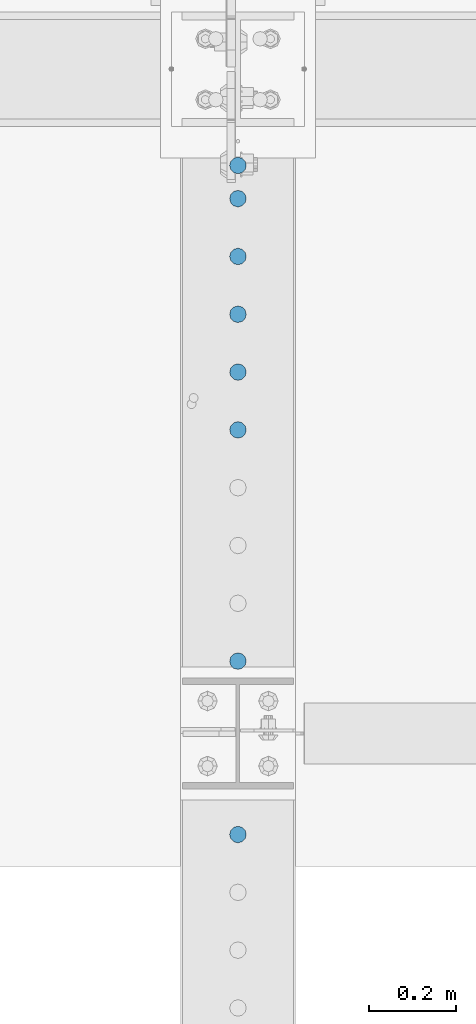
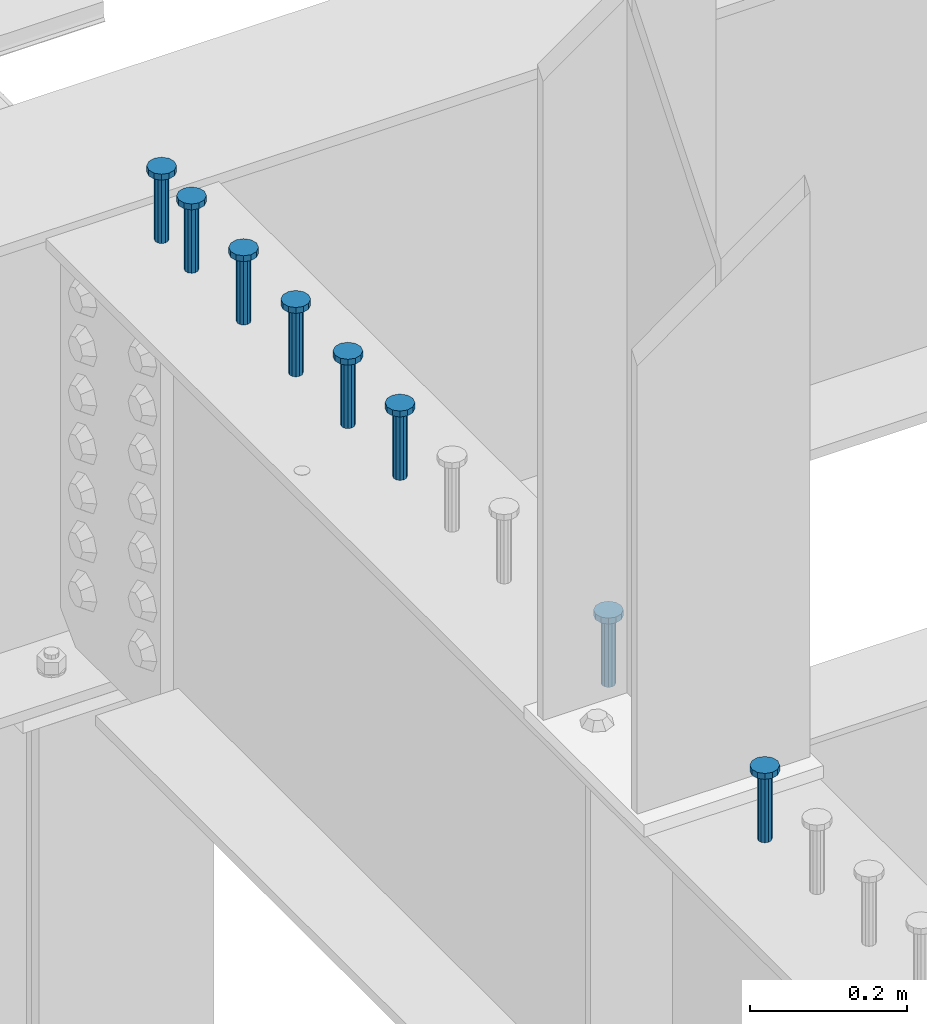
# One storey, part 950 of 1763: 8 columns, 8 elements without a shape of their own.
"""IFC2X3 building model written with IfcOpenShell, lengths in millimetres."""

import ifcopenshell
import ifcopenshell.guid

model = None  # the IFC model being written
_history = None  # IfcOwnerHistory: only IFC2X3 demands one
_inside = {}  # id of a spatial element -> (the spatial element, [elements in it])
_under = {}  # id of a project, library or spatial element -> (it, [spatial elements below it])
_declared = {}  # id of a project -> (the project, [libraries it declares])
_typed = {}  # id of a type object -> (the type object, [elements of that type])
_made_of = {}  # id of a material, layer set ... -> (it, [elements and type objects made of it])


def new_model(schema):
    """Start an empty IFC model of exactly this schema.

    Asked for "IFC4X3", IfcOpenShell would pick the latest addendum, in which some entities
    have other attributes; the version numbers below select the first issue.
    IFC2X3 requires an IfcOwnerHistory on every rooted entity: one is made here for all.
    """
    global model, _history
    if schema == "IFC4X3":
        model = ifcopenshell.file(schema_version=(4, 3, 0, 0))
    else:
        model = ifcopenshell.file(schema=schema)
    _inside.clear()
    _under.clear()
    _declared.clear()
    _typed.clear()
    _made_of.clear()
    _history = None
    if model.schema == "IFC2X3":
        org = make("IfcOrganization", Name="unknown")
        user = make(
            "IfcPersonAndOrganization",
            ThePerson=make("IfcPerson", FamilyName="unknown"),
            TheOrganization=org,
        )
        app = make(
            "IfcApplication",
            ApplicationDeveloper=org,
            Version="unknown",
            ApplicationFullName="unknown",
            ApplicationIdentifier="unknown",
        )
        _history = make(
            "IfcOwnerHistory",
            OwningUser=user,
            OwningApplication=app,
            ChangeAction="ADDED",
            CreationDate=0,
        )
    return model


def make(cls, **values):
    """One entity of the class cls with the attributes given. An attribute that is None is left unset."""
    return model.create_entity(
        cls, **{name: value for name, value in values.items() if value is not None}
    )


def rooted(cls, **values):
    """An entity with a GlobalId (a new one), such as an element, a storey or a relation."""
    return make(cls, GlobalId=ifcopenshell.guid.new(), OwnerHistory=_history, **values)


def si_unit(unit_type, name, prefix=None):
    """IfcSIUnit, for example si_unit("LENGTHUNIT", "METRE", prefix="MILLI")."""
    return make("IfcSIUnit", UnitType=unit_type, Prefix=prefix, Name=name)


def assignment(units):
    """IfcUnitAssignment: the units of a project."""
    return None if units is None else make("IfcUnitAssignment", Units=units)


def point(xyz):
    """IfcCartesianPoint."""
    return None if xyz is None else make("IfcCartesianPoint", Coordinates=xyz)


def direction(xyz):
    """IfcDirection."""
    return None if xyz is None else make("IfcDirection", DirectionRatios=xyz)


def frame(location, z_axis=None, x_axis=None):
    """IfcAxis2Placement3D, a coordinate frame: its origin and axes. An axis left out is left unset."""
    return make(
        "IfcAxis2Placement3D",
        Location=point(location),
        Axis=direction(z_axis),
        RefDirection=direction(x_axis),
    )


def origin_with_axes():
    """The frame at (0, 0, 0) with the z axis (0, 0, 1) and the x axis (1, 0, 0) written out."""
    return frame((0.0, 0.0, 0.0), z_axis=(0.0, 0.0, 1.0), x_axis=(1.0, 0.0, 0.0))


def place(relative_to, where):
    """IfcLocalPlacement: puts the frame where relative to a parent placement (None: the world)."""
    return make(
        "IfcLocalPlacement", PlacementRelTo=relative_to, RelativePlacement=where
    )


def context(
    kind, dimensions, precision=None, world=None, true_north=None, identifier=None
):
    """IfcGeometricRepresentationContext, for example the 3D "Model" context."""
    return make(
        "IfcGeometricRepresentationContext",
        ContextIdentifier=identifier,
        ContextType=kind,
        CoordinateSpaceDimension=dimensions,
        Precision=precision,
        WorldCoordinateSystem=world,
        TrueNorth=true_north,
    )


def subcontext(parent, identifier, kind, view, scale=None):
    """IfcGeometricRepresentationSubContext, for example "Body" below "Model"."""
    return make(
        "IfcGeometricRepresentationSubContext",
        ContextIdentifier=identifier,
        ContextType=kind,
        ParentContext=parent,
        TargetScale=scale,
        TargetView=view,
    )


def project(units=None, contexts=None):
    """IfcProject with its units and contexts."""
    return rooted(
        "IfcProject",
        Name="project",
        RepresentationContexts=contexts,
        UnitsInContext=assignment(units),
    )


def spatial(cls, under=None, at=None, **own):
    """A site, building, storey or space (cls), placed at a placement, below another one or the project."""
    s = rooted(cls, ObjectPlacement=at, **own)
    if under is not None:
        _under.setdefault(under.id(), (under, []))[1].append(s)
    return s


def faces_of(points, faces, orient=None, outer=None):
    """IfcFace entities. A face is a list of loops; a loop is a list of indices into points, from 0.

    orient and outer hold one flag for each loop. By default every Orientation is true, the
    first loop of a face is its IfcFaceOuterBound and the others are IfcFaceBound.
    """
    made = []
    for i, loops in enumerate(faces):
        bounds = []
        for j, loop in enumerate(loops):
            is_outer = j == 0 if outer is None else outer[i][j]
            bounds.append(
                make(
                    "IfcFaceOuterBound" if is_outer else "IfcFaceBound",
                    Bound=make("IfcPolyLoop", Polygon=[points[k] for k in loop]),
                    Orientation=True if orient is None else orient[i][j],
                )
            )
        made.append(make("IfcFace", Bounds=bounds))
    return made


def faceted_brep(points, faces, orient=None, outer=None, voids=None):
    """IfcFacetedBrep: a solid bounded by flat faces; with voids (closed shells), ...WithVoids."""
    shared = [point(p) for p in points]
    hull = make("IfcClosedShell", CfsFaces=faces_of(shared, faces, orient, outer))
    if voids is None:
        return make("IfcFacetedBrep", Outer=hull)
    return make(
        "IfcFacetedBrepWithVoids",
        Outer=hull,
        Voids=[
            make(cls, CfsFaces=faces_of(shared, fs, o, b)) for cls, fs, o, b in voids
        ],
    )


def shape(context_of_items, identifier, shape_type, items):
    """IfcShapeRepresentation: the items that make up one representation, for example the "Body"."""
    return make(
        "IfcShapeRepresentation",
        ContextOfItems=context_of_items,
        RepresentationIdentifier=identifier,
        RepresentationType=shape_type,
        Items=items,
    )


def material(Name=None, Category=None):
    """IfcMaterial."""
    return make("IfcMaterial", Name=Name, Category=Category)


def made_of(thing, what):
    """Note that an element or type object is made of a material, layer set ...; save() writes the relation."""
    if what is not None:
        _made_of.setdefault(what.id(), (what, []))[1].append(thing)
    return thing


def type_object(cls, material=None, **own):
    """A type object (cls), such as IfcWallType, which elements share."""
    return made_of(rooted(cls, **own), material)


def element(
    cls,
    number,
    at=None,
    inside=None,
    cuts=None,
    type_object=None,
    material=None,
    context=None,
    identifier="Body",
    shape_type=None,
    held_by="IfcProductDefinitionShape",
    body=None,
    shapes=None,
    **own,
):
    """One element of the class cls, such as IfcWall. Its Tag is "e" and its number.

    at: its placement. inside: the storey or other place that contains it. cuts: it is an
    opening in that element (IfcRelVoidsElement). A single representation is given by context,
    identifier, shape_type and body (its items); several are given by shapes. held_by: the class
    of the entity that holds the representations. save() writes the other relations.
    """
    e = rooted(cls, Tag="e%d" % number, ObjectPlacement=at, **own)
    if body is not None:
        shapes = [shape(context, identifier, shape_type, body)]
    if shapes is not None:
        e.Representation = make(held_by, Representations=shapes)
    if inside is not None:
        _inside.setdefault(inside.id(), (inside, []))[1].append(e)
    if cuts is not None:
        rooted(
            "IfcRelVoidsElement", RelatingBuildingElement=cuts, RelatedOpeningElement=e
        )
    if type_object is not None:
        _typed.setdefault(type_object.id(), (type_object, []))[1].append(e)
    return made_of(e, material)


def aggregate(whole, parts):
    """IfcRelAggregates: a whole, such as a stair, and the parts it consists of."""
    return rooted("IfcRelAggregates", RelatingObject=whole, RelatedObjects=parts)


def save(model, path):
    """Write the relations noted so far, then the file.

    IfcRelAggregates (storeys below a building ...), IfcRelContainedInSpatialStructure (elements
    in a storey), IfcRelDefinesByType, IfcRelAssociatesMaterial and IfcRelDeclares: one each for
    every whole, place, type object, material and project.
    """
    for whole, parts in _under.values():
        aggregate(whole, parts)
    for where, things in _inside.values():
        rooted(
            "IfcRelContainedInSpatialStructure",
            RelatedElements=things,
            RelatingStructure=where,
        )
    for kind, things in _typed.values():
        rooted("IfcRelDefinesByType", RelatedObjects=things, RelatingType=kind)
    for what, things in _made_of.values():
        rooted("IfcRelAssociatesMaterial", RelatedObjects=things, RelatingMaterial=what)
    for by, libraries in _declared.values():
        rooted("IfcRelDeclares", RelatingContext=by, RelatedDefinitions=libraries)
    model.write(path)


model = new_model("IFC2X3")

# Units and contexts
model_context = context("Model", 3, precision=1e-05, world=origin_with_axes())
body_context = subcontext(model_context, "Body", "Model", "MODEL_VIEW")
ifc_project = project(units=[si_unit("LENGTHUNIT", "METRE", prefix="MILLI"), si_unit("AREAUNIT", "SQUARE_METRE"), si_unit("VOLUMEUNIT", "CUBIC_METRE"), si_unit("MASSUNIT", "GRAM", prefix="KILO"), si_unit("TIMEUNIT", "SECOND"), si_unit("PLANEANGLEUNIT", "RADIAN"), si_unit("SOLIDANGLEUNIT", "STERADIAN"), si_unit("THERMODYNAMICTEMPERATUREUNIT", "DEGREE_CELSIUS"), si_unit("LUMINOUSINTENSITYUNIT", "LUMEN")], contexts=[model_context])

# Site, building, storey
site_placement = place(None, origin_with_axes())
site = spatial("IfcSite", under=ifc_project, at=site_placement, CompositionType="ELEMENT")
building_placement = place(site_placement, origin_with_axes())
building = spatial("IfcBuilding", under=site, at=building_placement, Name="Undefined", CompositionType="ELEMENT")
storey_placement = place(building_placement, origin_with_axes())
storey = spatial("IfcBuildingStorey", under=building, at=storey_placement, Name="Undefined", CompositionType="ELEMENT", Elevation=0.0)

# Assembly, column
assembly_1_placement = place(storey_placement, origin_with_axes())
assembly_1 = element("IfcElementAssembly", 1, at=assembly_1_placement, inside=storey, Name="STUD", AssemblyPlace="NOTDEFINED", PredefinedType="RIGID_FRAME")
ifc_material = material(Name="STEEL/A108")
column_type = type_object("IfcColumnType", Name="STUD_3/4-DIA", PredefinedType="NOTDEFINED")
column_1_placement = place(assembly_1_placement, frame((-24027.8372736984, 44584.9185, 5194.3), z_axis=(-1.0, 0.0, 0.0), x_axis=(0.0, 0.0, 1.0)))
column_1 = element("IfcColumn", 2, at=column_1_placement, type_object=column_type, material=ifc_material, Name="STUD", ObjectType="STUD_3/4-DIA", context=body_context, shape_type="Brep", body=[
    faceted_brep([(0.0, -9.52000045776367, 0.0), (0.0, -8.25, -4.76000022888184), (104.013, -8.25, -4.76000022888184), (104.013, -9.52000045776367, 0.0), (0.0, -4.76000022888184, -8.25), (104.013, -4.76000022888184, -8.25), (0.0, 0.0, -9.52000045776367), (104.013, 0.0, -9.52000045776367), (0.0, 4.76000022888184, -8.25), (104.013, 4.76000022888184, -8.25), (0.0, 8.25, -4.76000022888184), (104.013, 8.25, -4.76000022888184), (0.0, 9.52000045776367, 0.0), (104.013, 9.52000045776367, 0.0), (0.0, 8.25, 4.76000022888184), (104.013, 8.25, 4.76000022888184), (0.0, 4.76000022888184, 8.25), (104.013, 4.76000022888184, 8.25), (0.0, 0.0, 9.52000045776367), (104.013, 0.0, 9.52000045776367), (0.0, -4.76000022888184, 8.25), (104.013, -4.76000022888184, 8.25), (0.0, -8.25, 4.76000022888184), (104.013, -8.25, 4.76000022888184), (105.156, -16.5, -9.52000045776367), (105.156, -19.0499992370605, 0.0), (105.156, -9.52000045776367, -16.5), (105.156, 0.0, -19.0499992370605), (105.156, 9.52000045776367, -16.5), (105.156, 16.5, -9.52000045776367), (105.156, 19.0499992370605, 0.0), (105.156, 16.5, 9.52000045776367), (105.156, 9.52000045776367, 16.5), (105.156, 0.0, 19.0499992370605), (105.156, -9.52000045776367, 16.5), (105.156, -16.5, 9.52000045776367), (114.3, -16.5, -9.52000045776367), (114.299998441489, -19.0500000000029, 0.0), (114.3, -9.52000045776367, -16.5), (114.3, 0.0, -19.0499992370605), (114.3, 9.52000045776367, -16.5), (114.3, 16.5, -9.52000045776367), (114.299998441489, 19.0500000000029, 0.0), (114.3, 16.5, 9.52000045776367), (114.3, 9.52000045776367, 16.5), (114.3, 0.0, 19.0499992370605), (114.3, -9.52000045776367, 16.5), (114.3, -16.5, 9.52000045776367)], [[[0, 1, 2, 3]], [[1, 4, 5, 2]], [[4, 6, 7, 5]], [[6, 8, 9, 7]], [[8, 10, 11, 9]], [[10, 12, 13, 11]], [[12, 14, 15, 13]], [[14, 16, 17, 15]], [[16, 18, 19, 17]], [[18, 20, 21, 19]], [[20, 22, 23, 21]], [[22, 0, 3, 23]], [[22, 20, 18, 16, 14, 12, 10, 8, 6, 4, 1, 0]], [[3, 2, 24, 25]], [[2, 5, 26, 24]], [[5, 7, 27, 26]], [[7, 9, 28, 27]], [[9, 11, 29, 28]], [[11, 13, 30, 29]], [[13, 15, 31, 30]], [[15, 17, 32, 31]], [[17, 19, 33, 32]], [[19, 21, 34, 33]], [[21, 23, 35, 34]], [[23, 3, 25, 35]], [[25, 24, 36, 37]], [[24, 26, 38, 36]], [[26, 27, 39, 38]], [[27, 28, 40, 39]], [[28, 29, 41, 40]], [[29, 30, 42, 41]], [[30, 31, 43, 42]], [[31, 32, 44, 43]], [[32, 33, 45, 44]], [[33, 34, 46, 45]], [[34, 35, 47, 46]], [[35, 25, 37, 47]], [[38, 39, 40, 41, 42, 43, 44, 45, 46, 47, 37, 36]]]),
])
aggregate(assembly_1, [column_1])

assembly_2_placement = place(storey_placement, origin_with_axes())
assembly_2 = element("IfcElementAssembly", 3, at=assembly_2_placement, inside=storey, Name="STUD", AssemblyPlace="NOTDEFINED", PredefinedType="RIGID_FRAME")
column_2_placement = place(assembly_2_placement, frame((-24027.8372736984, 44508.7185, 5194.3), z_axis=(-1.0, 0.0, 0.0), x_axis=(0.0, 0.0, 1.0)))
column_2 = element("IfcColumn", 4, at=column_2_placement, type_object=column_type, material=ifc_material, Name="STUD", ObjectType="STUD_3/4-DIA", context=body_context, shape_type="Brep", body=[
    faceted_brep([(0.0, -9.52000045776367, 0.0), (0.0, -8.25, -4.76000022888184), (104.013, -8.25, -4.76000022888184), (104.013, -9.52000045776367, 0.0), (0.0, -4.76000022888184, -8.25), (104.013, -4.76000022888184, -8.25), (0.0, 0.0, -9.52000045776367), (104.013, 0.0, -9.52000045776367), (0.0, 4.76000022888184, -8.25), (104.013, 4.76000022888184, -8.25), (0.0, 8.25, -4.76000022888184), (104.013, 8.25, -4.76000022888184), (0.0, 9.52000045776367, 0.0), (104.013, 9.52000045776367, 0.0), (0.0, 8.25, 4.76000022888184), (104.013, 8.25, 4.76000022888184), (0.0, 4.76000022888184, 8.25), (104.013, 4.76000022888184, 8.25), (0.0, 0.0, 9.52000045776367), (104.013, 0.0, 9.52000045776367), (0.0, -4.76000022888184, 8.25), (104.013, -4.76000022888184, 8.25), (0.0, -8.25, 4.76000022888184), (104.013, -8.25, 4.76000022888184), (105.156, -16.5, -9.52000045776367), (105.156, -19.0499992370605, 0.0), (105.156, -9.52000045776367, -16.5), (105.156, 0.0, -19.0499992370605), (105.156, 9.52000045776367, -16.5), (105.156, 16.5, -9.52000045776367), (105.156, 19.0499992370605, 0.0), (105.156, 16.5, 9.52000045776367), (105.156, 9.52000045776367, 16.5), (105.156, 0.0, 19.0499992370605), (105.156, -9.52000045776367, 16.5), (105.156, -16.5, 9.52000045776367), (114.3, -16.5, -9.52000045776367), (114.299998441489, -19.0500000000029, 0.0), (114.3, -9.52000045776367, -16.5), (114.3, 0.0, -19.0499992370605), (114.3, 9.52000045776367, -16.5), (114.3, 16.5, -9.52000045776367), (114.299998441489, 19.0500000000029, 0.0), (114.3, 16.5, 9.52000045776367), (114.3, 9.52000045776367, 16.5), (114.3, 0.0, 19.0499992370605), (114.3, -9.52000045776367, 16.5), (114.3, -16.5, 9.52000045776367)], [[[0, 1, 2, 3]], [[1, 4, 5, 2]], [[4, 6, 7, 5]], [[6, 8, 9, 7]], [[8, 10, 11, 9]], [[10, 12, 13, 11]], [[12, 14, 15, 13]], [[14, 16, 17, 15]], [[16, 18, 19, 17]], [[18, 20, 21, 19]], [[20, 22, 23, 21]], [[22, 0, 3, 23]], [[22, 20, 18, 16, 14, 12, 10, 8, 6, 4, 1, 0]], [[3, 2, 24, 25]], [[2, 5, 26, 24]], [[5, 7, 27, 26]], [[7, 9, 28, 27]], [[9, 11, 29, 28]], [[11, 13, 30, 29]], [[13, 15, 31, 30]], [[15, 17, 32, 31]], [[17, 19, 33, 32]], [[19, 21, 34, 33]], [[21, 23, 35, 34]], [[23, 3, 25, 35]], [[25, 24, 36, 37]], [[24, 26, 38, 36]], [[26, 27, 39, 38]], [[27, 28, 40, 39]], [[28, 29, 41, 40]], [[29, 30, 42, 41]], [[30, 31, 43, 42]], [[31, 32, 44, 43]], [[32, 33, 45, 44]], [[33, 34, 46, 45]], [[34, 35, 47, 46]], [[35, 25, 37, 47]], [[38, 39, 40, 41, 42, 43, 44, 45, 46, 47, 37, 36]]]),
])
aggregate(assembly_2, [column_2])

assembly_3_placement = place(storey_placement, origin_with_axes())
assembly_3 = element("IfcElementAssembly", 5, at=assembly_3_placement, inside=storey, Name="STUD", AssemblyPlace="NOTDEFINED", PredefinedType="RIGID_FRAME")
column_3_placement = place(assembly_3_placement, frame((-24027.8372736984, 44376.1105, 5194.3), z_axis=(-1.0, 0.0, 0.0), x_axis=(0.0, 0.0, 1.0)))
column_3 = element("IfcColumn", 6, at=column_3_placement, type_object=column_type, material=ifc_material, Name="STUD", ObjectType="STUD_3/4-DIA", context=body_context, shape_type="Brep", body=[
    faceted_brep([(0.0, -9.52000045776367, 0.0), (0.0, -8.25, -4.76000022888184), (104.013, -8.25, -4.76000022888184), (104.013, -9.52000045776367, 0.0), (0.0, -4.76000022888184, -8.25), (104.013, -4.76000022888184, -8.25), (0.0, 0.0, -9.52000045776367), (104.013, 0.0, -9.52000045776367), (0.0, 4.76000022888184, -8.25), (104.013, 4.76000022888184, -8.25), (0.0, 8.25, -4.76000022888184), (104.013, 8.25, -4.76000022888184), (0.0, 9.52000045776367, 0.0), (104.013, 9.52000045776367, 0.0), (0.0, 8.25, 4.76000022888184), (104.013, 8.25, 4.76000022888184), (0.0, 4.76000022888184, 8.25), (104.013, 4.76000022888184, 8.25), (0.0, 0.0, 9.52000045776367), (104.013, 0.0, 9.52000045776367), (0.0, -4.76000022888184, 8.25), (104.013, -4.76000022888184, 8.25), (0.0, -8.25, 4.76000022888184), (104.013, -8.25, 4.76000022888184), (105.156, -16.5, -9.52000045776367), (105.156, -19.0499992370605, 0.0), (105.156, -9.52000045776367, -16.5), (105.156, 0.0, -19.0499992370605), (105.156, 9.52000045776367, -16.5), (105.156, 16.5, -9.52000045776367), (105.156, 19.0499992370605, 0.0), (105.156, 16.5, 9.52000045776367), (105.156, 9.52000045776367, 16.5), (105.156, 0.0, 19.0499992370605), (105.156, -9.52000045776367, 16.5), (105.156, -16.5, 9.52000045776367), (114.3, -16.5, -9.52000045776367), (114.299998441489, -19.0500000000029, 0.0), (114.3, -9.52000045776367, -16.5), (114.3, 0.0, -19.0499992370605), (114.3, 9.52000045776367, -16.5), (114.3, 16.5, -9.52000045776367), (114.299998441489, 19.0500000000029, 0.0), (114.3, 16.5, 9.52000045776367), (114.3, 9.52000045776367, 16.5), (114.3, 0.0, 19.0499992370605), (114.3, -9.52000045776367, 16.5), (114.3, -16.5, 9.52000045776367)], [[[0, 1, 2, 3]], [[1, 4, 5, 2]], [[4, 6, 7, 5]], [[6, 8, 9, 7]], [[8, 10, 11, 9]], [[10, 12, 13, 11]], [[12, 14, 15, 13]], [[14, 16, 17, 15]], [[16, 18, 19, 17]], [[18, 20, 21, 19]], [[20, 22, 23, 21]], [[22, 0, 3, 23]], [[22, 20, 18, 16, 14, 12, 10, 8, 6, 4, 1, 0]], [[3, 2, 24, 25]], [[2, 5, 26, 24]], [[5, 7, 27, 26]], [[7, 9, 28, 27]], [[9, 11, 29, 28]], [[11, 13, 30, 29]], [[13, 15, 31, 30]], [[15, 17, 32, 31]], [[17, 19, 33, 32]], [[19, 21, 34, 33]], [[21, 23, 35, 34]], [[23, 3, 25, 35]], [[25, 24, 36, 37]], [[24, 26, 38, 36]], [[26, 27, 39, 38]], [[27, 28, 40, 39]], [[28, 29, 41, 40]], [[29, 30, 42, 41]], [[30, 31, 43, 42]], [[31, 32, 44, 43]], [[32, 33, 45, 44]], [[33, 34, 46, 45]], [[34, 35, 47, 46]], [[35, 25, 37, 47]], [[38, 39, 40, 41, 42, 43, 44, 45, 46, 47, 37, 36]]]),
])
aggregate(assembly_3, [column_3])

assembly_4_placement = place(storey_placement, origin_with_axes())
assembly_4 = element("IfcElementAssembly", 7, at=assembly_4_placement, inside=storey, Name="STUD", AssemblyPlace="NOTDEFINED", PredefinedType="RIGID_FRAME")
column_4_placement = place(assembly_4_placement, frame((-24027.8372736984, 44243.5025, 5194.3), z_axis=(-1.0, 0.0, 0.0), x_axis=(0.0, 0.0, 1.0)))
column_4 = element("IfcColumn", 8, at=column_4_placement, type_object=column_type, material=ifc_material, Name="STUD", ObjectType="STUD_3/4-DIA", context=body_context, shape_type="Brep", body=[
    faceted_brep([(0.0, -9.52000045776367, 0.0), (0.0, -8.25, -4.76000022888184), (104.013, -8.25, -4.76000022888184), (104.013, -9.52000045776367, 0.0), (0.0, -4.76000022888184, -8.25), (104.013, -4.76000022888184, -8.25), (0.0, 0.0, -9.52000045776367), (104.013, 0.0, -9.52000045776367), (0.0, 4.76000022888184, -8.25), (104.013, 4.76000022888184, -8.25), (0.0, 8.25, -4.76000022888184), (104.013, 8.25, -4.76000022888184), (0.0, 9.52000045776367, 0.0), (104.013, 9.52000045776367, 0.0), (0.0, 8.25, 4.76000022888184), (104.013, 8.25, 4.76000022888184), (0.0, 4.76000022888184, 8.25), (104.013, 4.76000022888184, 8.25), (0.0, 0.0, 9.52000045776367), (104.013, 0.0, 9.52000045776367), (0.0, -4.76000022888184, 8.25), (104.013, -4.76000022888184, 8.25), (0.0, -8.25, 4.76000022888184), (104.013, -8.25, 4.76000022888184), (105.156, -16.5, -9.52000045776367), (105.156, -19.0499992370605, 0.0), (105.156, -9.52000045776367, -16.5), (105.156, 0.0, -19.0499992370605), (105.156, 9.52000045776367, -16.5), (105.156, 16.5, -9.52000045776367), (105.156, 19.0499992370605, 0.0), (105.156, 16.5, 9.52000045776367), (105.156, 9.52000045776367, 16.5), (105.156, 0.0, 19.0499992370605), (105.156, -9.52000045776367, 16.5), (105.156, -16.5, 9.52000045776367), (114.3, -16.5, -9.52000045776367), (114.299998441489, -19.0500000000029, 0.0), (114.3, -9.52000045776367, -16.5), (114.3, 0.0, -19.0499992370605), (114.3, 9.52000045776367, -16.5), (114.3, 16.5, -9.52000045776367), (114.299998441489, 19.0500000000029, 0.0), (114.3, 16.5, 9.52000045776367), (114.3, 9.52000045776367, 16.5), (114.3, 0.0, 19.0499992370605), (114.3, -9.52000045776367, 16.5), (114.3, -16.5, 9.52000045776367)], [[[0, 1, 2, 3]], [[1, 4, 5, 2]], [[4, 6, 7, 5]], [[6, 8, 9, 7]], [[8, 10, 11, 9]], [[10, 12, 13, 11]], [[12, 14, 15, 13]], [[14, 16, 17, 15]], [[16, 18, 19, 17]], [[18, 20, 21, 19]], [[20, 22, 23, 21]], [[22, 0, 3, 23]], [[22, 20, 18, 16, 14, 12, 10, 8, 6, 4, 1, 0]], [[3, 2, 24, 25]], [[2, 5, 26, 24]], [[5, 7, 27, 26]], [[7, 9, 28, 27]], [[9, 11, 29, 28]], [[11, 13, 30, 29]], [[13, 15, 31, 30]], [[15, 17, 32, 31]], [[17, 19, 33, 32]], [[19, 21, 34, 33]], [[21, 23, 35, 34]], [[23, 3, 25, 35]], [[25, 24, 36, 37]], [[24, 26, 38, 36]], [[26, 27, 39, 38]], [[27, 28, 40, 39]], [[28, 29, 41, 40]], [[29, 30, 42, 41]], [[30, 31, 43, 42]], [[31, 32, 44, 43]], [[32, 33, 45, 44]], [[33, 34, 46, 45]], [[34, 35, 47, 46]], [[35, 25, 37, 47]], [[38, 39, 40, 41, 42, 43, 44, 45, 46, 47, 37, 36]]]),
])
aggregate(assembly_4, [column_4])

assembly_5_placement = place(storey_placement, origin_with_axes())
assembly_5 = element("IfcElementAssembly", 9, at=assembly_5_placement, inside=storey, Name="STUD", AssemblyPlace="NOTDEFINED", PredefinedType="RIGID_FRAME")
column_5_placement = place(assembly_5_placement, frame((-24027.8372736984, 44110.8945, 5194.3), z_axis=(-1.0, 0.0, 0.0), x_axis=(0.0, 0.0, 1.0)))
column_5 = element("IfcColumn", 10, at=column_5_placement, type_object=column_type, material=ifc_material, Name="STUD", ObjectType="STUD_3/4-DIA", context=body_context, shape_type="Brep", body=[
    faceted_brep([(0.0, -9.52000045776367, 0.0), (0.0, -8.25, -4.76000022888184), (104.013, -8.25, -4.76000022888184), (104.013, -9.52000045776367, 0.0), (0.0, -4.76000022888184, -8.25), (104.013, -4.76000022888184, -8.25), (0.0, 0.0, -9.52000045776367), (104.013, 0.0, -9.52000045776367), (0.0, 4.76000022888184, -8.25), (104.013, 4.76000022888184, -8.25), (0.0, 8.25, -4.76000022888184), (104.013, 8.25, -4.76000022888184), (0.0, 9.52000045776367, 0.0), (104.013, 9.52000045776367, 0.0), (0.0, 8.25, 4.76000022888184), (104.013, 8.25, 4.76000022888184), (0.0, 4.76000022888184, 8.25), (104.013, 4.76000022888184, 8.25), (0.0, 0.0, 9.52000045776367), (104.013, 0.0, 9.52000045776367), (0.0, -4.76000022888184, 8.25), (104.013, -4.76000022888184, 8.25), (0.0, -8.25, 4.76000022888184), (104.013, -8.25, 4.76000022888184), (105.156, -16.5, -9.52000045776367), (105.156, -19.0499992370605, 0.0), (105.156, -9.52000045776367, -16.5), (105.156, 0.0, -19.0499992370605), (105.156, 9.52000045776367, -16.5), (105.156, 16.5, -9.52000045776367), (105.156, 19.0499992370605, 0.0), (105.156, 16.5, 9.52000045776367), (105.156, 9.52000045776367, 16.5), (105.156, 0.0, 19.0499992370605), (105.156, -9.52000045776367, 16.5), (105.156, -16.5, 9.52000045776367), (114.3, -16.5, -9.52000045776367), (114.299998441489, -19.0500000000029, 0.0), (114.3, -9.52000045776367, -16.5), (114.3, 0.0, -19.0499992370605), (114.3, 9.52000045776367, -16.5), (114.3, 16.5, -9.52000045776367), (114.299998441489, 19.0500000000029, 0.0), (114.3, 16.5, 9.52000045776367), (114.3, 9.52000045776367, 16.5), (114.3, 0.0, 19.0499992370605), (114.3, -9.52000045776367, 16.5), (114.3, -16.5, 9.52000045776367)], [[[0, 1, 2, 3]], [[1, 4, 5, 2]], [[4, 6, 7, 5]], [[6, 8, 9, 7]], [[8, 10, 11, 9]], [[10, 12, 13, 11]], [[12, 14, 15, 13]], [[14, 16, 17, 15]], [[16, 18, 19, 17]], [[18, 20, 21, 19]], [[20, 22, 23, 21]], [[22, 0, 3, 23]], [[22, 20, 18, 16, 14, 12, 10, 8, 6, 4, 1, 0]], [[3, 2, 24, 25]], [[2, 5, 26, 24]], [[5, 7, 27, 26]], [[7, 9, 28, 27]], [[9, 11, 29, 28]], [[11, 13, 30, 29]], [[13, 15, 31, 30]], [[15, 17, 32, 31]], [[17, 19, 33, 32]], [[19, 21, 34, 33]], [[21, 23, 35, 34]], [[23, 3, 25, 35]], [[25, 24, 36, 37]], [[24, 26, 38, 36]], [[26, 27, 39, 38]], [[27, 28, 40, 39]], [[28, 29, 41, 40]], [[29, 30, 42, 41]], [[30, 31, 43, 42]], [[31, 32, 44, 43]], [[32, 33, 45, 44]], [[33, 34, 46, 45]], [[34, 35, 47, 46]], [[35, 25, 37, 47]], [[38, 39, 40, 41, 42, 43, 44, 45, 46, 47, 37, 36]]]),
])
aggregate(assembly_5, [column_5])

assembly_6_placement = place(storey_placement, origin_with_axes())
assembly_6 = element("IfcElementAssembly", 11, at=assembly_6_placement, inside=storey, Name="STUD", AssemblyPlace="NOTDEFINED", PredefinedType="RIGID_FRAME")
column_6_placement = place(assembly_6_placement, frame((-24027.8372736984, 43978.2865, 5194.3), z_axis=(-1.0, 0.0, 0.0), x_axis=(0.0, 0.0, 1.0)))
column_6 = element("IfcColumn", 12, at=column_6_placement, type_object=column_type, material=ifc_material, Name="STUD", ObjectType="STUD_3/4-DIA", context=body_context, shape_type="Brep", body=[
    faceted_brep([(0.0, -9.52000045776367, 0.0), (0.0, -8.25, -4.76000022888184), (104.013, -8.25, -4.76000022888184), (104.013, -9.52000045776367, 0.0), (0.0, -4.76000022888184, -8.25), (104.013, -4.76000022888184, -8.25), (0.0, 0.0, -9.52000045776367), (104.013, 0.0, -9.52000045776367), (0.0, 4.76000022888184, -8.25), (104.013, 4.76000022888184, -8.25), (0.0, 8.25, -4.76000022888184), (104.013, 8.25, -4.76000022888184), (0.0, 9.52000045776367, 0.0), (104.013, 9.52000045776367, 0.0), (0.0, 8.25, 4.76000022888184), (104.013, 8.25, 4.76000022888184), (0.0, 4.76000022888184, 8.25), (104.013, 4.76000022888184, 8.25), (0.0, 0.0, 9.52000045776367), (104.013, 0.0, 9.52000045776367), (0.0, -4.76000022888184, 8.25), (104.013, -4.76000022888184, 8.25), (0.0, -8.25, 4.76000022888184), (104.013, -8.25, 4.76000022888184), (105.156, -16.5, -9.52000045776367), (105.156, -19.0499992370605, 0.0), (105.156, -9.52000045776367, -16.5), (105.156, 0.0, -19.0499992370605), (105.156, 9.52000045776367, -16.5), (105.156, 16.5, -9.52000045776367), (105.156, 19.0499992370605, 0.0), (105.156, 16.5, 9.52000045776367), (105.156, 9.52000045776367, 16.5), (105.156, 0.0, 19.0499992370605), (105.156, -9.52000045776367, 16.5), (105.156, -16.5, 9.52000045776367), (114.3, -16.5, -9.52000045776367), (114.299998441489, -19.0500000000029, 0.0), (114.3, -9.52000045776367, -16.5), (114.3, 0.0, -19.0499992370605), (114.3, 9.52000045776367, -16.5), (114.3, 16.5, -9.52000045776367), (114.299998441489, 19.0500000000029, 0.0), (114.3, 16.5, 9.52000045776367), (114.3, 9.52000045776367, 16.5), (114.3, 0.0, 19.0499992370605), (114.3, -9.52000045776367, 16.5), (114.3, -16.5, 9.52000045776367)], [[[0, 1, 2, 3]], [[1, 4, 5, 2]], [[4, 6, 7, 5]], [[6, 8, 9, 7]], [[8, 10, 11, 9]], [[10, 12, 13, 11]], [[12, 14, 15, 13]], [[14, 16, 17, 15]], [[16, 18, 19, 17]], [[18, 20, 21, 19]], [[20, 22, 23, 21]], [[22, 0, 3, 23]], [[22, 20, 18, 16, 14, 12, 10, 8, 6, 4, 1, 0]], [[3, 2, 24, 25]], [[2, 5, 26, 24]], [[5, 7, 27, 26]], [[7, 9, 28, 27]], [[9, 11, 29, 28]], [[11, 13, 30, 29]], [[13, 15, 31, 30]], [[15, 17, 32, 31]], [[17, 19, 33, 32]], [[19, 21, 34, 33]], [[21, 23, 35, 34]], [[23, 3, 25, 35]], [[25, 24, 36, 37]], [[24, 26, 38, 36]], [[26, 27, 39, 38]], [[27, 28, 40, 39]], [[28, 29, 41, 40]], [[29, 30, 42, 41]], [[30, 31, 43, 42]], [[31, 32, 44, 43]], [[32, 33, 45, 44]], [[33, 34, 46, 45]], [[34, 35, 47, 46]], [[35, 25, 37, 47]], [[38, 39, 40, 41, 42, 43, 44, 45, 46, 47, 37, 36]]]),
])
aggregate(assembly_6, [column_6])

assembly_7_placement = place(storey_placement, origin_with_axes())
assembly_7 = element("IfcElementAssembly", 13, at=assembly_7_placement, inside=storey, Name="STUD", AssemblyPlace="NOTDEFINED", PredefinedType="RIGID_FRAME")
column_7_placement = place(assembly_7_placement, frame((-24027.8372736984, 43447.8545, 5194.3), z_axis=(-1.0, 0.0, 0.0), x_axis=(0.0, 0.0, 1.0)))
column_7 = element("IfcColumn", 14, at=column_7_placement, type_object=column_type, material=ifc_material, Name="STUD", ObjectType="STUD_3/4-DIA", context=body_context, shape_type="Brep", body=[
    faceted_brep([(0.0, -9.52000045776367, 0.0), (0.0, -8.25, -4.76000022888184), (104.013, -8.25, -4.76000022888184), (104.013, -9.52000045776367, 0.0), (0.0, -4.76000022888184, -8.25), (104.013, -4.76000022888184, -8.25), (0.0, 0.0, -9.52000045776367), (104.013, 0.0, -9.52000045776367), (0.0, 4.76000022888184, -8.25), (104.013, 4.76000022888184, -8.25), (0.0, 8.25, -4.76000022888184), (104.013, 8.25, -4.76000022888184), (0.0, 9.52000045776367, 0.0), (104.013, 9.52000045776367, 0.0), (0.0, 8.25, 4.76000022888184), (104.013, 8.25, 4.76000022888184), (0.0, 4.76000022888184, 8.25), (104.013, 4.76000022888184, 8.25), (0.0, 0.0, 9.52000045776367), (104.013, 0.0, 9.52000045776367), (0.0, -4.76000022888184, 8.25), (104.013, -4.76000022888184, 8.25), (0.0, -8.25, 4.76000022888184), (104.013, -8.25, 4.76000022888184), (105.156, -16.5, -9.52000045776367), (105.156, -19.0499992370605, 0.0), (105.156, -9.52000045776367, -16.5), (105.156, 0.0, -19.0499992370605), (105.156, 9.52000045776367, -16.5), (105.156, 16.5, -9.52000045776367), (105.156, 19.0499992370605, 0.0), (105.156, 16.5, 9.52000045776367), (105.156, 9.52000045776367, 16.5), (105.156, 0.0, 19.0499992370605), (105.156, -9.52000045776367, 16.5), (105.156, -16.5, 9.52000045776367), (114.3, -16.5, -9.52000045776367), (114.299998441489, -19.0500000000029, 0.0), (114.3, -9.52000045776367, -16.5), (114.3, 0.0, -19.0499992370605), (114.3, 9.52000045776367, -16.5), (114.3, 16.5, -9.52000045776367), (114.299998441489, 19.0500000000029, 0.0), (114.3, 16.5, 9.52000045776367), (114.3, 9.52000045776367, 16.5), (114.3, 0.0, 19.0499992370605), (114.3, -9.52000045776367, 16.5), (114.3, -16.5, 9.52000045776367)], [[[0, 1, 2, 3]], [[1, 4, 5, 2]], [[4, 6, 7, 5]], [[6, 8, 9, 7]], [[8, 10, 11, 9]], [[10, 12, 13, 11]], [[12, 14, 15, 13]], [[14, 16, 17, 15]], [[16, 18, 19, 17]], [[18, 20, 21, 19]], [[20, 22, 23, 21]], [[22, 0, 3, 23]], [[22, 20, 18, 16, 14, 12, 10, 8, 6, 4, 1, 0]], [[3, 2, 24, 25]], [[2, 5, 26, 24]], [[5, 7, 27, 26]], [[7, 9, 28, 27]], [[9, 11, 29, 28]], [[11, 13, 30, 29]], [[13, 15, 31, 30]], [[15, 17, 32, 31]], [[17, 19, 33, 32]], [[19, 21, 34, 33]], [[21, 23, 35, 34]], [[23, 3, 25, 35]], [[25, 24, 36, 37]], [[24, 26, 38, 36]], [[26, 27, 39, 38]], [[27, 28, 40, 39]], [[28, 29, 41, 40]], [[29, 30, 42, 41]], [[30, 31, 43, 42]], [[31, 32, 44, 43]], [[32, 33, 45, 44]], [[33, 34, 46, 45]], [[34, 35, 47, 46]], [[35, 25, 37, 47]], [[38, 39, 40, 41, 42, 43, 44, 45, 46, 47, 37, 36]]]),
])
aggregate(assembly_7, [column_7])

assembly_8_placement = place(storey_placement, origin_with_axes())
assembly_8 = element("IfcElementAssembly", 15, at=assembly_8_placement, inside=storey, Name="STUD", AssemblyPlace="NOTDEFINED", PredefinedType="RIGID_FRAME")
column_8_placement = place(assembly_8_placement, frame((-24027.8372736984, 43050.0305, 5194.3), z_axis=(-1.0, 0.0, 0.0), x_axis=(0.0, 0.0, 1.0)))
column_8 = element("IfcColumn", 16, at=column_8_placement, type_object=column_type, material=ifc_material, Name="STUD", ObjectType="STUD_3/4-DIA", context=body_context, shape_type="Brep", body=[
    faceted_brep([(0.0, -9.52000045776367, 0.0), (0.0, -8.25, -4.76000022888184), (104.013, -8.25, -4.76000022888184), (104.013, -9.52000045776367, 0.0), (0.0, -4.76000022888184, -8.25), (104.013, -4.76000022888184, -8.25), (0.0, 0.0, -9.52000045776367), (104.013, 0.0, -9.52000045776367), (0.0, 4.76000022888184, -8.25), (104.013, 4.76000022888184, -8.25), (0.0, 8.25, -4.76000022888184), (104.013, 8.25, -4.76000022888184), (0.0, 9.52000045776367, 0.0), (104.013, 9.52000045776367, 0.0), (0.0, 8.25, 4.76000022888184), (104.013, 8.25, 4.76000022888184), (0.0, 4.76000022888184, 8.25), (104.013, 4.76000022888184, 8.25), (0.0, 0.0, 9.52000045776367), (104.013, 0.0, 9.52000045776367), (0.0, -4.76000022888184, 8.25), (104.013, -4.76000022888184, 8.25), (0.0, -8.25, 4.76000022888184), (104.013, -8.25, 4.76000022888184), (105.156, -16.5, -9.52000045776367), (105.156, -19.0499992370605, 0.0), (105.156, -9.52000045776367, -16.5), (105.156, 0.0, -19.0499992370605), (105.156, 9.52000045776367, -16.5), (105.156, 16.5, -9.52000045776367), (105.156, 19.0499992370605, 0.0), (105.156, 16.5, 9.52000045776367), (105.156, 9.52000045776367, 16.5), (105.156, 0.0, 19.0499992370605), (105.156, -9.52000045776367, 16.5), (105.156, -16.5, 9.52000045776367), (114.3, -16.5, -9.52000045776367), (114.299998441489, -19.0500000000029, 0.0), (114.3, -9.52000045776367, -16.5), (114.3, 0.0, -19.0499992370605), (114.3, 9.52000045776367, -16.5), (114.3, 16.5, -9.52000045776367), (114.299998441489, 19.0500000000029, 0.0), (114.3, 16.5, 9.52000045776367), (114.3, 9.52000045776367, 16.5), (114.3, 0.0, 19.0499992370605), (114.3, -9.52000045776367, 16.5), (114.3, -16.5, 9.52000045776367)], [[[0, 1, 2, 3]], [[1, 4, 5, 2]], [[4, 6, 7, 5]], [[6, 8, 9, 7]], [[8, 10, 11, 9]], [[10, 12, 13, 11]], [[12, 14, 15, 13]], [[14, 16, 17, 15]], [[16, 18, 19, 17]], [[18, 20, 21, 19]], [[20, 22, 23, 21]], [[22, 0, 3, 23]], [[22, 20, 18, 16, 14, 12, 10, 8, 6, 4, 1, 0]], [[3, 2, 24, 25]], [[2, 5, 26, 24]], [[5, 7, 27, 26]], [[7, 9, 28, 27]], [[9, 11, 29, 28]], [[11, 13, 30, 29]], [[13, 15, 31, 30]], [[15, 17, 32, 31]], [[17, 19, 33, 32]], [[19, 21, 34, 33]], [[21, 23, 35, 34]], [[23, 3, 25, 35]], [[25, 24, 36, 37]], [[24, 26, 38, 36]], [[26, 27, 39, 38]], [[27, 28, 40, 39]], [[28, 29, 41, 40]], [[29, 30, 42, 41]], [[30, 31, 43, 42]], [[31, 32, 44, 43]], [[32, 33, 45, 44]], [[33, 34, 46, 45]], [[34, 35, 47, 46]], [[35, 25, 37, 47]], [[38, 39, 40, 41, 42, 43, 44, 45, 46, 47, 37, 36]]]),
])
aggregate(assembly_8, [column_8])

save(model, "model.ifc")
